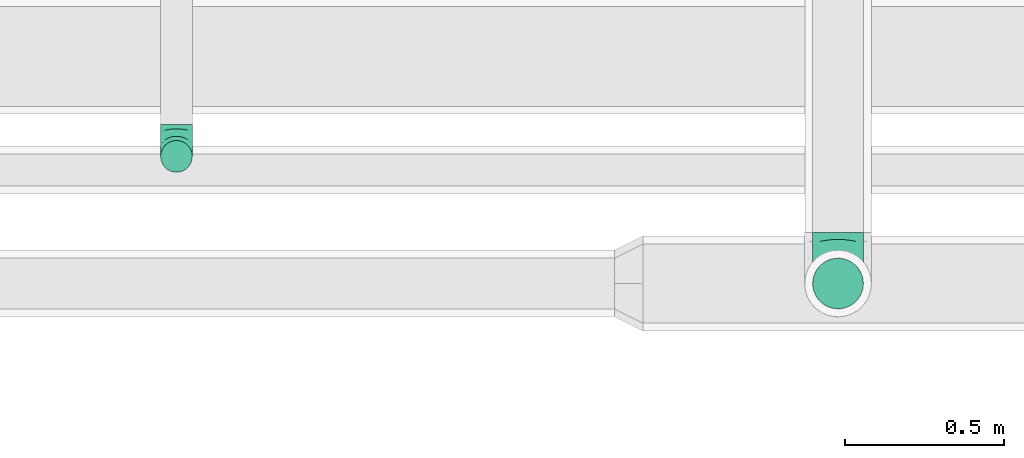
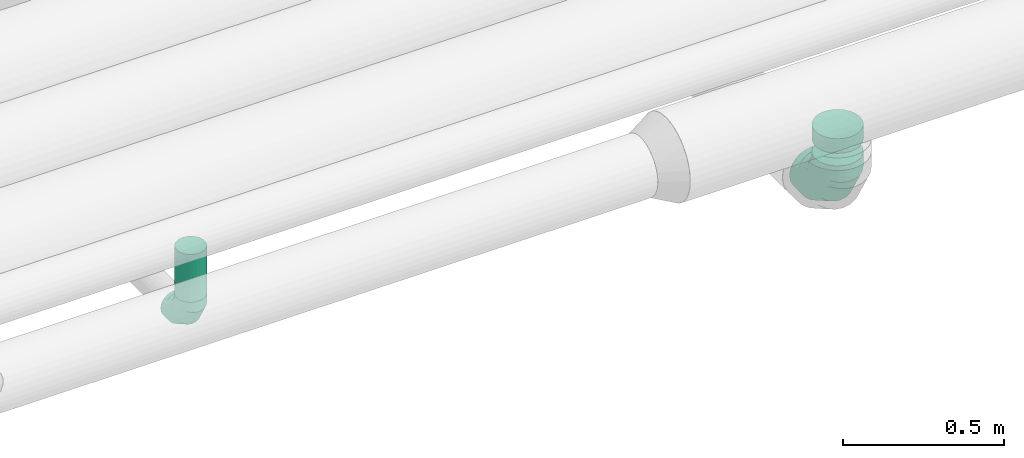
# One storey, part 47 of 92: 3 flow fittings, 1 flow segment.
"""IFC2X3 building model written with IfcOpenShell, lengths in millimetres."""

from ifc_helpers import new_model, entity, si_unit, converted_unit, derived_unit, direction, frame, origin, origin_2d_with_axis, place, context, subcontext, project, spatial, circle, extrude, faceted_brep, source, transform, mapped, material, type_object, type_shapes, element, save


model = new_model("IFC2X3")

# Units and contexts
model_context = context("Model", 3, precision=0.01, world=origin(), true_north=direction((6.12303176911189e-17, 1.0)))
body_context = subcontext(model_context, "Body", "Model", "MODEL_VIEW")
ifc_project = project(units=[si_unit("LENGTHUNIT", "METRE", prefix="MILLI"), si_unit("AREAUNIT", "SQUARE_METRE"), si_unit("VOLUMEUNIT", "CUBIC_METRE"), converted_unit("PLANEANGLEUNIT", "DEGREE", entity("IfcRatioMeasure", 0.0174532925199433), si_unit("PLANEANGLEUNIT", "RADIAN"), dimensions=[0, 0, 0, 0, 0, 0, 0]), si_unit("MASSUNIT", "GRAM", prefix="KILO"), derived_unit("MASSDENSITYUNIT", [(si_unit("MASSUNIT", "GRAM", prefix="KILO"), 1), (si_unit("LENGTHUNIT", "METRE"), -3)]), derived_unit("MOMENTOFINERTIAUNIT", [(si_unit("LENGTHUNIT", "METRE"), 4)]), si_unit("TIMEUNIT", "SECOND"), si_unit("FREQUENCYUNIT", "HERTZ"), si_unit("THERMODYNAMICTEMPERATUREUNIT", "DEGREE_CELSIUS"), derived_unit("THERMALTRANSMITTANCEUNIT", [(si_unit("MASSUNIT", "GRAM", prefix="KILO"), 1), (si_unit("THERMODYNAMICTEMPERATUREUNIT", "KELVIN"), -1), (si_unit("TIMEUNIT", "SECOND"), -3)]), derived_unit("VOLUMETRICFLOWRATEUNIT", [(si_unit("LENGTHUNIT", "METRE"), 3), (si_unit("TIMEUNIT", "SECOND"), -1)]), derived_unit("MASSFLOWRATEUNIT", [(si_unit("MASSUNIT", "GRAM", prefix="KILO"), 1), (si_unit("TIMEUNIT", "SECOND"), -1)]), derived_unit("ROTATIONALFREQUENCYUNIT", [(si_unit("TIMEUNIT", "SECOND"), -1)]), si_unit("ELECTRICCURRENTUNIT", "AMPERE"), si_unit("ELECTRICVOLTAGEUNIT", "VOLT"), si_unit("POWERUNIT", "WATT"), si_unit("FORCEUNIT", "NEWTON", prefix="KILO"), si_unit("ILLUMINANCEUNIT", "LUX"), si_unit("LUMINOUSFLUXUNIT", "LUMEN"), si_unit("LUMINOUSINTENSITYUNIT", "CANDELA"), derived_unit("USERDEFINED", [(si_unit("MASSUNIT", "GRAM", prefix="KILO"), -1), (si_unit("LENGTHUNIT", "METRE"), -2), (si_unit("TIMEUNIT", "SECOND"), 3), (si_unit("LUMINOUSFLUXUNIT", "LUMEN"), 1)]), derived_unit("LINEARVELOCITYUNIT", [(si_unit("LENGTHUNIT", "METRE"), 1), (si_unit("TIMEUNIT", "SECOND"), -1)]), si_unit("PRESSUREUNIT", "PASCAL"), derived_unit("USERDEFINED", [(si_unit("LENGTHUNIT", "METRE"), -2), (si_unit("MASSUNIT", "GRAM", prefix="KILO"), 1), (si_unit("TIMEUNIT", "SECOND"), -2)]), derived_unit("LINEARFORCEUNIT", [(si_unit("MASSUNIT", "GRAM", prefix="KILO"), 1), (si_unit("LENGTHUNIT", "METRE"), 1), (si_unit("TIMEUNIT", "SECOND"), -2), (si_unit("LENGTHUNIT", "METRE"), -1)]), derived_unit("PLANARFORCEUNIT", [(si_unit("MASSUNIT", "GRAM", prefix="KILO"), 1), (si_unit("LENGTHUNIT", "METRE"), 1), (si_unit("TIMEUNIT", "SECOND"), -2), (si_unit("LENGTHUNIT", "METRE"), -2)])], contexts=[model_context])

# Site, building, storey
site_placement = place(None, origin())
site = spatial("IfcSite", under=ifc_project, at=site_placement, CompositionType="ELEMENT")
building_placement = place(site_placement, origin())
building = spatial("IfcBuilding", under=site, at=building_placement, CompositionType="ELEMENT")
storey_placement = place(building_placement, frame((0.0, 0.0, 4200.0)))
storey = spatial("IfcBuildingStorey", under=building, at=storey_placement, CompositionType="ELEMENT", Elevation=4200.0)

# Flow segment
duct_segment_type = type_object("IfcDuctSegmentType", PredefinedType="NOTDEFINED")
flow_segment_placement = place(storey_placement, frame((29380.97, 14590.4, 3100.0)))
element("IfcFlowSegment", 1, at=flow_segment_placement, inside=storey, type_object=duct_segment_type, context=body_context, shape_type="SweptSolid", body=[
    extrude(circle(Radius=50.0, at=origin_2d_with_axis()), frame((51.6, 51.6, 0.0)), (0.0, 0.0, 1.0), 180.565700166783),
])

# Flow fittings
ifc_material = material()
duct_fitting_type_1 = type_object("IfcDuctFittingType", PredefinedType="NOTDEFINED", material=ifc_material)
shared_shape_1 = source(origin(), body_context, "Body", "Brep", [
    faceted_brep([(-160.0, 0.0, -80.0), (-160.0, -20.71, -77.27), (-160.0, -40.0, -69.28), (-160.0, -56.57, -56.57), (-160.0, -69.28, -40.0), (-160.0, -77.27, -20.71), (-160.0, -80.0, 0.0), (-160.0, -77.27, 20.71), (-160.0, -69.28, 40.0), (-160.0, -56.57, 56.57), (-160.0, -40.0, 69.28), (-160.0, -20.71, 77.27), (-160.0, 0.0, 80.0), (-160.0, 20.71, 77.27), (-160.0, 40.0, 69.28), (-160.0, 56.57, 56.57), (-160.0, 69.28, 40.0), (-160.0, 77.27, 20.71), (-160.0, 80.0, 0.0), (-160.0, 77.27, -20.71), (-160.0, 69.28, -40.0), (-160.0, 56.57, -56.57), (-160.0, 40.0, -69.28), (-160.0, 20.71, -77.27), (-122.68, 20.71, 77.27), (-127.85, 40.0, 69.28), (-117.13, 0.0, 80.0), (-132.29, 56.57, 56.57), (-137.83, 77.27, 20.71), (-138.56, 80.0, 0.0), (-135.69, 69.28, 40.0), (-135.69, 69.28, -40.0), (-132.29, 56.57, -56.57), (-137.83, 77.27, -20.71), (-122.68, 20.71, -77.27), (-117.13, 0.0, -80.0), (-127.85, 40.0, -69.28), (-111.58, -20.71, -77.27), (-106.41, -40.0, -69.28), (-101.97, -56.57, -56.57), (-98.56, -69.28, -40.0), (-96.42, -77.27, -20.71), (-95.69, -80.0, 0.0), (-96.42, -77.27, 20.71), (-98.56, -69.28, 40.0), (-101.97, -56.57, 56.57), (-106.41, -40.0, 69.28), (-111.58, -20.71, 77.27), (-58.03, 58.03, 77.27), (-72.15, 72.15, 69.28), (-42.87, 42.87, 80.0), (-84.28, 84.28, 56.57), (-93.59, 93.59, 40.0), (-99.44, 99.44, 20.71), (-101.44, 101.44, 0.0), (-99.44, 99.44, -20.71), (-93.59, 93.59, -40.0), (-84.28, 84.28, -56.57), (-58.03, 58.03, -77.27), (-42.87, 42.87, -80.0), (-72.15, 72.15, -69.28), (-27.71, 27.71, -77.27), (-13.59, 13.59, -69.28), (-1.46, 1.46, -56.57), (7.85, -7.85, -40.0), (13.7, -13.7, -20.71), (15.69, -15.69, 0.0), (13.7, -13.7, 20.71), (7.85, -7.85, 40.0), (-1.46, 1.46, 56.57), (-13.59, 13.59, 69.28), (-27.71, 27.71, 77.27), (-20.71, 122.68, 77.27), (-40.0, 127.85, 69.28), (0.0, 117.13, 80.0), (-56.57, 132.29, 56.57), (-69.28, 135.69, 40.0), (-77.27, 137.83, 20.71), (-80.0, 138.56, 0.0), (-77.27, 137.83, -20.71), (-69.28, 135.69, -40.0), (-56.57, 132.29, -56.57), (-20.71, 122.68, -77.27), (0.0, 117.13, -80.0), (-40.0, 127.85, -69.28), (20.71, 111.58, -77.27), (40.0, 106.41, -69.28), (56.57, 101.97, -56.57), (69.28, 98.56, -40.0), (77.27, 96.42, -20.71), (80.0, 95.69, 0.0), (77.27, 96.42, 20.71), (69.28, 98.56, 40.0), (56.57, 101.97, 56.57), (40.0, 106.41, 69.28), (20.71, 111.58, 77.27), (-20.71, 160.0, -77.27), (-40.0, 160.0, -69.28), (-56.57, 160.0, -56.57), (-69.28, 160.0, -40.0), (-77.27, 160.0, -20.71), (-80.0, 160.0, 0.0), (-77.27, 160.0, 20.71), (-69.28, 160.0, 40.0), (-56.57, 160.0, 56.57), (-40.0, 160.0, 69.28), (-20.71, 160.0, 77.27), (0.0, 160.0, 80.0), (20.71, 160.0, 77.27), (40.0, 160.0, 69.28), (56.57, 160.0, 56.57), (69.28, 160.0, 40.0), (77.27, 160.0, 20.71), (80.0, 160.0, 0.0), (77.27, 160.0, -20.71), (69.28, 160.0, -40.0), (56.57, 160.0, -56.57), (40.0, 160.0, -69.28), (20.71, 160.0, -77.27), (0.0, 160.0, -80.0)], [[[0, 1, 2, 3, 4, 5, 6, 7, 8, 9, 10, 11, 12, 13, 14, 15, 16, 17, 18, 19, 20, 21, 22, 23]], [[24, 25, 14, 13]], [[26, 24, 13, 12]], [[14, 25, 27, 15]], [[28, 29, 18, 17]], [[30, 28, 17, 16]], [[15, 27, 30, 16]], [[20, 31, 32, 21]], [[33, 31, 20, 19]], [[18, 29, 33, 19]], [[34, 35, 0, 23]], [[36, 34, 23, 22]], [[32, 36, 22, 21]], [[1, 0, 35, 37]], [[2, 1, 37, 38]], [[3, 2, 38, 39]], [[5, 4, 40, 41]], [[6, 5, 41, 42]], [[39, 40, 4, 3]], [[6, 42, 43, 7]], [[7, 43, 44, 8]], [[8, 44, 45, 9]], [[9, 45, 46, 10]], [[10, 46, 47, 11]], [[26, 12, 11, 47]], [[48, 49, 25, 24]], [[50, 48, 24, 26]], [[27, 25, 49, 51]], [[52, 53, 28, 30]], [[51, 52, 30, 27]], [[29, 28, 53, 54]], [[55, 56, 31, 33]], [[54, 55, 33, 29]], [[32, 31, 56, 57]], [[58, 59, 35, 34]], [[60, 58, 34, 36]], [[57, 60, 36, 32]], [[37, 35, 59, 61]], [[38, 37, 61, 62]], [[39, 38, 62, 63]], [[41, 40, 64, 65]], [[42, 41, 65, 66]], [[63, 64, 40, 39]], [[43, 42, 66, 67]], [[44, 43, 67, 68]], [[68, 69, 45, 44]], [[46, 45, 69, 70]], [[47, 46, 70, 71]], [[26, 47, 71, 50]], [[72, 73, 49, 48]], [[74, 72, 48, 50]], [[51, 49, 73, 75]], [[76, 77, 53, 52]], [[75, 76, 52, 51]], [[54, 53, 77, 78]], [[79, 80, 56, 55]], [[78, 79, 55, 54]], [[57, 56, 80, 81]], [[82, 83, 59, 58]], [[84, 82, 58, 60]], [[81, 84, 60, 57]], [[61, 59, 83, 85]], [[62, 61, 85, 86]], [[63, 62, 86, 87]], [[65, 64, 88, 89]], [[66, 65, 89, 90]], [[87, 88, 64, 63]], [[67, 66, 90, 91]], [[68, 67, 91, 92]], [[92, 93, 69, 68]], [[70, 69, 93, 94]], [[71, 70, 94, 95]], [[50, 71, 95, 74]], [[96, 97, 98, 99, 100, 101, 102, 103, 104, 105, 106, 107, 108, 109, 110, 111, 112, 113, 114, 115, 116, 117, 118, 119]], [[72, 74, 107, 106]], [[73, 72, 106, 105]], [[75, 73, 105, 104]], [[77, 76, 103, 102]], [[78, 77, 102, 101]], [[75, 104, 103, 76]], [[78, 101, 100, 79]], [[79, 100, 99, 80]], [[80, 99, 98, 81]], [[84, 97, 96, 82]], [[82, 96, 119, 83]], [[84, 81, 98, 97]], [[118, 117, 86, 85]], [[119, 118, 85, 83]], [[116, 87, 86, 117]], [[88, 115, 114, 89]], [[89, 114, 113, 90]], [[115, 88, 87, 116]], [[112, 111, 92, 91]], [[113, 112, 91, 90]], [[111, 110, 93, 92]], [[95, 94, 109, 108]], [[74, 95, 108, 107]], [[110, 109, 94, 93]]]),
])
type_shapes(duct_fitting_type_1, [shared_shape_1])
flow_fitting_1_placement = place(storey_placement, frame((31515.0, 14242.0, 2990.0), z_axis=(1.0, 0.0, 0.0), x_axis=(0.0, 0.0, -1.0)))
element("IfcFlowFitting", 2, at=flow_fitting_1_placement, inside=storey, type_object=duct_fitting_type_1, material=ifc_material, context=body_context, shape_type="MappedRepresentation", body=[
    mapped(shared_shape_1, transform((0.0, 0.0, 0.0), scale=1.0)),
])
duct_fitting_type_2 = type_object("IfcDuctFittingType", PredefinedType="NOTDEFINED", material=ifc_material)
shared_shape_2 = source(origin(), body_context, "Body", "Brep", [
    faceted_brep([(-100.0, 0.0, -50.0), (-100.0, -12.94, -48.3), (-100.0, -25.0, -43.3), (-100.0, -35.36, -35.36), (-100.0, -43.3, -25.0), (-100.0, -48.3, -12.94), (-100.0, -50.0, 0.0), (-100.0, -48.3, 12.94), (-100.0, -43.3, 25.0), (-100.0, -35.36, 35.36), (-100.0, -25.0, 43.3), (-100.0, -12.94, 48.3), (-100.0, 0.0, 50.0), (-100.0, 12.94, 48.3), (-100.0, 25.0, 43.3), (-100.0, 35.36, 35.36), (-100.0, 43.3, 25.0), (-100.0, 48.3, 12.94), (-100.0, 50.0, 0.0), (-100.0, 48.3, -12.94), (-100.0, 43.3, -25.0), (-100.0, 35.36, -35.36), (-100.0, 25.0, -43.3), (-100.0, 12.94, -48.3), (-76.67, 12.94, 48.3), (-79.9, 25.0, 43.3), (-73.21, 0.0, 50.0), (-82.68, 35.36, 35.36), (-86.15, 48.3, 12.94), (-86.6, 50.0, 0.0), (-84.81, 43.3, 25.0), (-84.81, 43.3, -25.0), (-82.68, 35.36, -35.36), (-86.15, 48.3, -12.94), (-76.67, 12.94, -48.3), (-73.21, 0.0, -50.0), (-79.9, 25.0, -43.3), (-69.74, -12.94, -48.3), (-66.51, -25.0, -43.3), (-63.73, -35.36, -35.36), (-61.6, -43.3, -25.0), (-60.26, -48.3, -12.94), (-59.81, -50.0, 0.0), (-60.26, -48.3, 12.94), (-61.6, -43.3, 25.0), (-63.73, -35.36, 35.36), (-66.51, -25.0, 43.3), (-69.74, -12.94, 48.3), (-36.27, 36.27, 48.3), (-45.1, 45.1, 43.3), (-26.79, 26.79, 50.0), (-52.68, 52.68, 35.36), (-58.49, 58.49, 25.0), (-62.15, 62.15, 12.94), (-63.4, 63.4, 0.0), (-62.15, 62.15, -12.94), (-58.49, 58.49, -25.0), (-52.68, 52.68, -35.36), (-36.27, 36.27, -48.3), (-26.79, 26.79, -50.0), (-45.1, 45.1, -43.3), (-17.32, 17.32, -48.3), (-8.49, 8.49, -43.3), (-0.91, 0.91, -35.36), (4.9, -4.9, -25.0), (8.56, -8.56, -12.94), (9.81, -9.81, 0.0), (8.56, -8.56, 12.94), (4.9, -4.9, 25.0), (-0.91, 0.91, 35.36), (-8.49, 8.49, 43.3), (-17.32, 17.32, 48.3), (-12.94, 76.67, 48.3), (-25.0, 79.9, 43.3), (0.0, 73.21, 50.0), (-35.36, 82.68, 35.36), (-43.3, 84.81, 25.0), (-48.3, 86.15, 12.94), (-50.0, 86.6, 0.0), (-48.3, 86.15, -12.94), (-43.3, 84.81, -25.0), (-35.36, 82.68, -35.36), (-12.94, 76.67, -48.3), (0.0, 73.21, -50.0), (-25.0, 79.9, -43.3), (12.94, 69.74, -48.3), (25.0, 66.51, -43.3), (35.36, 63.73, -35.36), (43.3, 61.6, -25.0), (48.3, 60.26, -12.94), (50.0, 59.81, 0.0), (48.3, 60.26, 12.94), (43.3, 61.6, 25.0), (35.36, 63.73, 35.36), (25.0, 66.51, 43.3), (12.94, 69.74, 48.3), (-12.94, 100.0, -48.3), (-25.0, 100.0, -43.3), (-35.36, 100.0, -35.36), (-43.3, 100.0, -25.0), (-48.3, 100.0, -12.94), (-50.0, 100.0, 0.0), (-48.3, 100.0, 12.94), (-43.3, 100.0, 25.0), (-35.36, 100.0, 35.36), (-25.0, 100.0, 43.3), (-12.94, 100.0, 48.3), (0.0, 100.0, 50.0), (12.94, 100.0, 48.3), (25.0, 100.0, 43.3), (35.36, 100.0, 35.36), (43.3, 100.0, 25.0), (48.3, 100.0, 12.94), (50.0, 100.0, 0.0), (48.3, 100.0, -12.94), (43.3, 100.0, -25.0), (35.36, 100.0, -35.36), (25.0, 100.0, -43.3), (12.94, 100.0, -48.3), (0.0, 100.0, -50.0)], [[[0, 1, 2, 3, 4, 5, 6, 7, 8, 9, 10, 11, 12, 13, 14, 15, 16, 17, 18, 19, 20, 21, 22, 23]], [[24, 25, 14, 13]], [[26, 24, 13, 12]], [[14, 25, 27, 15]], [[28, 29, 18, 17]], [[30, 28, 17, 16]], [[15, 27, 30, 16]], [[20, 31, 32, 21]], [[33, 31, 20, 19]], [[18, 29, 33, 19]], [[34, 35, 0, 23]], [[36, 34, 23, 22]], [[32, 36, 22, 21]], [[2, 1, 37, 38]], [[3, 2, 38, 39]], [[0, 35, 37, 1]], [[5, 4, 40, 41]], [[6, 5, 41, 42]], [[3, 39, 40, 4]], [[6, 42, 43, 7]], [[7, 43, 44, 8]], [[8, 44, 45, 9]], [[10, 46, 47, 11]], [[11, 47, 26, 12]], [[10, 9, 45, 46]], [[48, 49, 25, 24]], [[50, 48, 24, 26]], [[27, 25, 49, 51]], [[52, 53, 28, 30]], [[51, 52, 30, 27]], [[29, 28, 53, 54]], [[55, 56, 31, 33]], [[54, 55, 33, 29]], [[57, 32, 31, 56]], [[58, 59, 35, 34]], [[60, 58, 34, 36]], [[57, 60, 36, 32]], [[37, 35, 59, 61]], [[38, 37, 61, 62]], [[39, 38, 62, 63]], [[41, 40, 64, 65]], [[42, 41, 65, 66]], [[63, 64, 40, 39]], [[43, 42, 66, 67]], [[44, 43, 67, 68]], [[68, 69, 45, 44]], [[46, 45, 69, 70]], [[47, 46, 70, 71]], [[26, 47, 71, 50]], [[72, 73, 49, 48]], [[74, 72, 48, 50]], [[51, 49, 73, 75]], [[76, 77, 53, 52]], [[75, 76, 52, 51]], [[54, 53, 77, 78]], [[79, 80, 56, 55]], [[78, 79, 55, 54]], [[81, 57, 56, 80]], [[82, 83, 59, 58]], [[84, 82, 58, 60]], [[81, 84, 60, 57]], [[61, 59, 83, 85]], [[62, 61, 85, 86]], [[63, 62, 86, 87]], [[65, 64, 88, 89]], [[66, 65, 89, 90]], [[87, 88, 64, 63]], [[67, 66, 90, 91]], [[68, 67, 91, 92]], [[92, 93, 69, 68]], [[70, 69, 93, 94]], [[71, 70, 94, 95]], [[50, 71, 95, 74]], [[96, 97, 98, 99, 100, 101, 102, 103, 104, 105, 106, 107, 108, 109, 110, 111, 112, 113, 114, 115, 116, 117, 118, 119]], [[72, 74, 107, 106]], [[73, 72, 106, 105]], [[75, 73, 105, 104]], [[77, 76, 103, 102]], [[78, 77, 102, 101]], [[75, 104, 103, 76]], [[78, 101, 100, 79]], [[79, 100, 99, 80]], [[80, 99, 98, 81]], [[96, 119, 83, 82]], [[97, 96, 82, 84]], [[84, 81, 98, 97]], [[83, 119, 118, 85]], [[85, 118, 117, 86]], [[86, 117, 116, 87]], [[88, 115, 114, 89]], [[89, 114, 113, 90]], [[87, 116, 115, 88]], [[91, 90, 113, 112]], [[92, 91, 112, 111]], [[93, 92, 111, 110]], [[95, 94, 109, 108]], [[74, 95, 108, 107]], [[110, 109, 94, 93]]]),
])
type_shapes(duct_fitting_type_2, [shared_shape_2])
flow_fitting_2_placement = place(storey_placement, frame((29432.56, 14642.0, 3000.0), z_axis=(1.0, 0.0, 0.0), x_axis=(0.0, 0.0, -1.0)))
element("IfcFlowFitting", 3, at=flow_fitting_2_placement, inside=storey, type_object=duct_fitting_type_2, material=ifc_material, context=body_context, shape_type="MappedRepresentation", body=[
    mapped(shared_shape_2, transform((0.0, 0.0, 0.0), scale=1.0)),
])
duct_fitting_type_3 = type_object("IfcDuctFittingType", PredefinedType="NOTDEFINED", material=ifc_material)
shared_shape_3 = source(origin(), body_context, "Body", "Brep", [
    faceted_brep([(20.0, 20.71, -77.27), (20.0, 40.0, -69.28), (20.0, 56.57, -56.57), (20.0, 69.28, -40.0), (20.0, 77.27, -20.71), (20.0, 80.0, 0.0), (20.0, 77.27, 20.71), (20.0, 69.28, 40.0), (20.0, 56.57, 56.57), (20.0, 40.0, 69.28), (20.0, 20.71, 77.27), (20.0, 0.0, 80.0), (20.0, -20.71, 77.27), (20.0, -40.0, 69.28), (20.0, -56.57, 56.57), (20.0, -69.28, 40.0), (20.0, -77.27, 20.71), (20.0, -80.0, 0.0), (20.0, -77.27, -20.71), (20.0, -69.28, -40.0), (20.0, -56.57, -56.57), (20.0, -40.0, -69.28), (20.0, -20.71, -77.27), (20.0, 0.0, -80.0), (0.0, 0.0, 80.0), (0.0, 20.71, 77.27), (-35.05, 20.71, 77.27), (-35.05, 0.0, 80.0), (0.0, 40.0, 69.28), (-35.05, 40.0, 69.28), (0.0, 56.57, 56.57), (-35.05, 56.57, 56.57), (0.0, 69.28, 40.0), (0.0, 77.27, 20.71), (-35.05, 77.27, 20.71), (-35.05, 69.28, 40.0), (0.0, 80.0, 0.0), (-35.05, 80.0, 0.0), (0.0, 77.27, -20.71), (-35.05, 77.27, -20.71), (0.0, 69.28, -40.0), (-35.05, 69.28, -40.0), (0.0, 56.57, -56.57), (-35.05, 56.57, -56.57), (0.0, 40.0, -69.28), (0.0, 20.71, -77.27), (-35.05, 20.71, -77.27), (-35.05, 40.0, -69.28), (0.0, 0.0, -80.0), (-35.05, 0.0, -80.0), (0.0, -20.71, -77.27), (-35.05, -20.71, -77.27), (0.0, -40.0, -69.28), (-35.05, -40.0, -69.28), (0.0, -56.57, -56.57), (-35.05, -56.57, -56.57), (0.0, -69.28, -40.0), (0.0, -77.27, -20.71), (-35.05, -77.27, -20.71), (-35.05, -69.28, -40.0), (0.0, -80.0, 0.0), (-35.05, -80.0, 0.0), (0.0, -77.27, 20.71), (-35.05, -77.27, 20.71), (0.0, -69.28, 40.0), (-35.05, -69.28, 40.0), (0.0, -56.57, 56.57), (-35.05, -56.57, 56.57), (0.0, -40.0, 69.28), (0.0, -20.71, 77.27), (-35.05, -20.71, 77.27), (-35.05, -40.0, 69.28)], [[[0, 1, 2, 3, 4, 5, 6, 7, 8, 9, 10, 11, 12, 13, 14, 15, 16, 17, 18, 19, 20, 21, 22, 23]], [[24, 11, 10, 25, 26, 27]], [[25, 10, 9, 28, 29, 26]], [[28, 9, 8, 30, 31, 29]], [[32, 7, 6, 33, 34, 35]], [[33, 6, 5, 36, 37, 34]], [[30, 8, 7, 32, 35, 31]], [[36, 5, 4, 38, 39, 37]], [[38, 4, 3, 40, 41, 39]], [[40, 3, 2, 42, 43, 41]], [[44, 1, 0, 45, 46, 47]], [[45, 0, 23, 48, 49, 46]], [[42, 2, 1, 44, 47, 43]], [[48, 23, 22, 50, 51, 49]], [[50, 22, 21, 52, 53, 51]], [[52, 21, 20, 54, 55, 53]], [[56, 19, 18, 57, 58, 59]], [[57, 18, 17, 60, 61, 58]], [[54, 20, 19, 56, 59, 55]], [[60, 17, 16, 62, 63, 61]], [[62, 16, 15, 64, 65, 63]], [[64, 15, 14, 66, 67, 65]], [[68, 13, 12, 69, 70, 71]], [[69, 12, 11, 24, 27, 70]], [[66, 14, 13, 68, 71, 67]], [[49, 51, 53, 55, 59, 58, 61, 63, 65, 67, 71, 70, 27, 26, 29, 31, 35, 34, 37, 39, 41, 43, 47, 46]]]),
])
type_shapes(duct_fitting_type_3, [shared_shape_3])
flow_fitting_3_placement = place(storey_placement, frame((31515.0, 14242.0, 3217.7), z_axis=(0.0, 1.0, 0.0), x_axis=(0.0, 0.0, -1.0)))
element("IfcFlowFitting", 4, at=flow_fitting_3_placement, inside=storey, type_object=duct_fitting_type_3, material=ifc_material, context=body_context, shape_type="MappedRepresentation", body=[
    mapped(shared_shape_3, transform((0.0, 0.0, 0.0), scale=1.0)),
])

save(model, "model.ifc")
